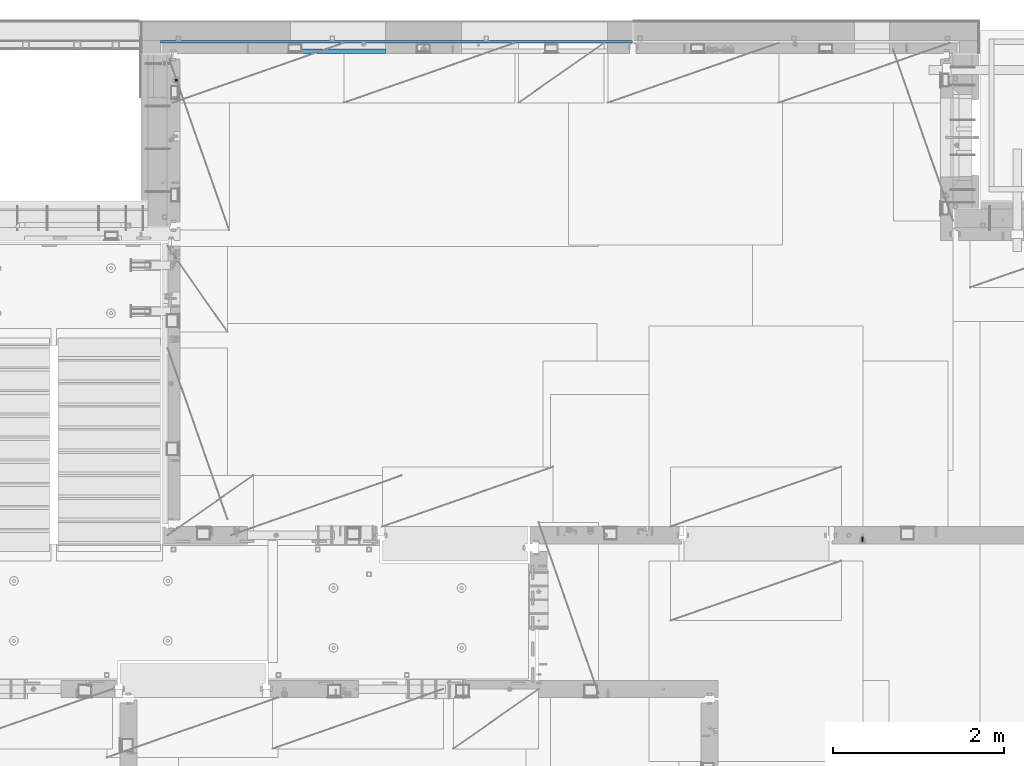
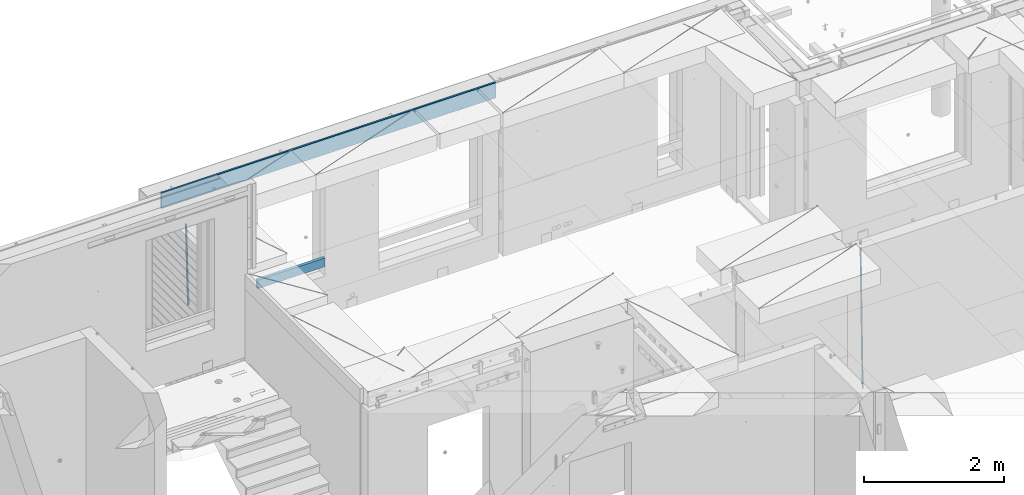
# One storey, part 126 of 350: 4 beams, 3 elements without a shape of their own.
"""IFC2X3 building model written with IfcOpenShell, lengths in millimetres."""

from ifc_helpers import new_model, si_unit, frame, origin_with_axes, place, context, subcontext, project, spatial, faceted_brep, material, type_object, element, aggregate, save


model = new_model("IFC2X3")

# Units and contexts
model_context = context("Model", 3, precision=1e-05, world=origin_with_axes())
body_context = subcontext(model_context, "Body", "Model", "MODEL_VIEW")
ifc_project = project(units=[si_unit("LENGTHUNIT", "METRE", prefix="MILLI"), si_unit("AREAUNIT", "SQUARE_METRE"), si_unit("VOLUMEUNIT", "CUBIC_METRE"), si_unit("MASSUNIT", "GRAM", prefix="KILO"), si_unit("TIMEUNIT", "SECOND"), si_unit("PLANEANGLEUNIT", "RADIAN"), si_unit("SOLIDANGLEUNIT", "STERADIAN"), si_unit("THERMODYNAMICTEMPERATUREUNIT", "DEGREE_CELSIUS"), si_unit("LUMINOUSINTENSITYUNIT", "LUMEN")], contexts=[model_context])

# Site, building, storey
site_placement = place(None, origin_with_axes())
site = spatial("IfcSite", under=ifc_project, at=site_placement, CompositionType="ELEMENT")
building_placement = place(site_placement, origin_with_axes())
building = spatial("IfcBuilding", under=site, at=building_placement, CompositionType="ELEMENT")
storey_placement = place(building_placement, origin_with_axes())
storey = spatial("IfcBuildingStorey", under=building, at=storey_placement, Name="2", CompositionType="ELEMENT", Elevation=0.0)

# Assembly, beam
assembly_1_placement = place(storey_placement, origin_with_axes())
assembly_1 = element("IfcElementAssembly", 1, at=assembly_1_placement, inside=storey, AssemblyPlace="NOTDEFINED", PredefinedType="REINFORCEMENT_UNIT")
ifc_material_1 = material()
beam_type_1 = type_object("IfcBeamType", Name="D20", PredefinedType="NOTDEFINED")
beam_1_placement = place(assembly_1_placement, frame((30400.0000000039, 16915.0002418615, 84990.0), z_axis=(-0.000205762999925498, 0.999642804629538, -0.0267249099901004), x_axis=(4.30000201928125e-08, 0.0267249099948059, 0.999642825806181)))
beam_1 = element("IfcBeam", 2, at=beam_1_placement, type_object=beam_type_1, material=ifc_material_1, Name="JM20", ObjectType="D20", context=body_context, shape_type="Brep", body=[
    faceted_brep([(0.0, -10.0, 0.0), (-4.19531716033816e-08, -7.07106781186667, -7.07106781187031), (60.4266690400545, -7.0710677960451, -7.07106780570757), (60.4266690441291, -9.99999998418934, 6.15546014159918e-09), (0.0, 0.0, -10.0), (60.426669036824, 1.58106558956206e-08, -9.99999999384454), (4.196772351861e-08, 7.07106781186303, -7.07106781186667), (60.4266690363438, 7.07106782768096, -7.07106780570757), (0.0, 10.0, 0.0), (60.4266690388904, 10.0000000158179, 6.15182216279209e-09), (4.196772351861e-08, 7.07106781185939, 7.07106781185939), (60.4266690429649, 7.07106782768096, 7.07106781802577), (0.0, 0.0, 10.0), (60.4266690461809, 1.58179318532348e-08, 10.0000000061555), (-4.19531716033816e-08, -7.07106781187031, 7.07106781185939), (60.4266690466611, -7.07106779605238, 7.07106781802213), (61.0378400410118, -7.07106779588503, -7.07106780564936), (60.991799419251, -9.99999998403655, 6.21366780251265e-09), (61.0569027789461, 1.5985278878361e-08, -9.99999999378269), (61.0378209396877, 7.07106782784831, -7.07106780564936), (60.9917724058905, 10.0000000159635, 6.21366780251265e-09), (60.9457317841297, 7.07106782781193, 7.0710678180767), (60.9266690461809, 1.59488990902901e-08, 10.0000000062028), (60.9457508854539, -7.07106779591413, 7.0710678180767), (61.6489592143771, -7.07106614513759, -7.06310863441468), (61.5568818710308, -9.9999984576425, 0.00735959856683621), (61.6870830769039, 1.71821739058942e-06, -9.99179257185824), (61.6489210170112, 7.07106947854481, -7.06310888312146), (61.556827851804, 10.0000015422847, 0.00735924683976918), (61.4647505084577, 7.07106922979438, 7.07782747982128), (61.4266266459163, 1.36643211590126e-06, 10.0065114172685), (61.464788705809, -7.07106639389531, 7.07782772852806), (176.543135720174, -7.07075579406956, -5.56673531796696), (176.451058376813, -9.99968810657447, 1.50373291501455), (176.581259582701, 0.000312069292704109, -8.49541925541052), (176.543097522794, 7.07137982961285, -5.56673556667374), (176.451004357587, 10.00031189336, 1.50373256329476), (176.35892701424, 7.07137958085514, 8.57420079627263), (176.320803151699, 0.000311717507429421, 11.5028847337162), (176.358965211621, -7.07075604281999, 8.57420104497578), (177.098753836006, -7.07075429323595, -5.55949898843028), (176.98362511232, -9.99968666800123, 1.510669025065), (177.146421932586, 0.000313595905026887, -8.48805862247536), (177.098706077581, 7.07138133041735, -5.55949936166144), (176.983557571715, 10.0003133318824, 1.51066849724157), (176.868428848029, 7.07138095712435, 8.58083651073321), (176.820760751449, 0.000313067976094317, 11.5093961447819), (176.868476606425, -7.07075466652896, 8.58083688396073), (177.654312950661, -7.07075204110879, -5.54863964998367), (177.516135294456, -9.99968450931192, 1.52107783331303), (177.711524267797, 0.000315886711177882, -8.47701274570863), (177.654255632195, 7.07138358250813, -5.54864021007961), (177.516054233929, 10.0003154905207, 1.5210770412159), (177.377876577739, 7.0713830223176, 8.59079452451624), (177.320665260588, 0.000315094497636892, 11.5191676202448), (177.377933896176, -7.07075260129932, 8.59079508461218), (299.499456785634, -7.07025810522464, -3.16697112782276), (299.361279129444, -9.99919057342777, 3.90274635547394), (299.556668102785, 0.000809822595329024, -6.09534422354773), (299.499399467197, 7.07187751838501, -3.1669716879187), (299.361198068917, 10.0008094264049, 3.90274556338045), (299.223020412712, 7.07187695819448, 10.9724630466735), (299.165809095575, 0.000809030381788034, 13.9008361423985), (299.223077731163, -7.07025866542244, 10.9724636067695), (300.03174732349, -7.07025594743027, -3.15656661289177), (299.971788958996, -9.99918809853989, 3.91467979818117), (300.056572611924, 0.000811849109595641, -6.08557274808481), (300.031722507032, 7.07187967631762, -3.15656653768019), (299.971753863239, 10.0008119014747, 3.91467990454839), (299.91179549876, 7.07187975035777, 10.9859263156177), (299.886970210311, 0.000811953817901667, 13.9149324508144), (299.911820315203, -7.0702558733974, 10.9859262404061), (300.564137759997, -7.07025623699155, -3.15794273276697), (300.582413367199, -9.99918843065097, 3.91310145956595), (300.556570941641, 0.000811577163403854, -6.0868651410201), (300.564145451674, 7.07187938674906, -3.15794274158179), (300.582424244858, 10.0008115693345, 3.91310144710224), (300.600699852032, 7.07187937566778, 10.9841456394352), (300.608266670402, 0.000811561512819026, 13.9130680476919), (300.600692160384, -7.07025624805829, 10.98414564825), (2294.16589219622, -7.0713405251372, -8.31099358700158), (2294.1841678034, -10.0002727187966, -1.23994939466866), (2294.15832537785, -0.000272710982244462, -11.2399159952547), (2294.16589988787, 7.07079509858886, -8.31099359582004), (2294.18417868105, 9.99972728118883, -1.23994940713601), (2294.20245428824, 7.07079508752213, 5.83109478519327), (2294.2100211066, -0.00027272663282929, 8.76001719345368), (2294.20244659658, -7.07134053620393, 5.83109479401173), (2294.7782683276, -7.07134085819416, -8.31257645345977), (2294.72126025338, -10.000273010919, -1.24133766827799), (2294.84007459224, -0.000273081772320438, -11.2416781768807), (2294.87047377572, 7.07079471537872, -8.31281477453012), (2294.85165844864, 9.9997269181622, -1.24167470516841), (2294.7946503744, 7.07079476544459, 5.82956408001337), (2294.73284410976, -0.000273010977252852, 8.75866580342336), (2294.7024449263, -7.07134080815013, 5.82980240107645), (2295.39054023061, -7.0793250091956, -8.30442771922026), (2295.25826128852, -10.0072756143927, -1.23419071494573), (2295.52170777075, -0.00916171800054144, -11.2326063125765), (2295.57492774284, 7.06160849139269, -8.30343918807193), (2295.51902460904, 9.99102432676591, -1.23279272078435), (2295.38674566693, 7.06307372157607, 5.83744428349019), (2295.25557812679, -0.0070895696117077, 8.76562287684646), (2295.20235815471, -7.07785977901949, 5.83645575234186), (2317.1947101649, -7.36365585014573, -8.01423575520312), (2317.06243122277, -10.2916064553428, -0.94399875092131), (2317.32587770502, -0.293492558957951, -10.9424143485521), (2317.37909767711, 6.77727765044983, -8.01324722405116), (2317.32319454331, 9.70669348581578, -0.942600756767206), (2317.1909156012, 6.77874288063322, 6.12763624751096), (2317.05974806109, -0.291420410569117, 9.0558148408636), (2317.00652808898, -7.36219061996962, 6.12664771636264), (2317.83015404257, -7.37194216843636, -8.00577862486898), (2317.72252095213, -10.300214160583, -0.935213608652703), (2317.90419832576, -0.301033978277701, -10.9347174723516), (2317.90127966482, 6.77046829039318, -8.00629749759901), (2317.82310777172, 9.70017451494641, -0.935947405505431), (2317.71547468127, 6.77190252279979, 6.13461761071085), (2317.64143039809, -0.29900566735887, 9.06355645819713), (2317.64434905903, -7.37050793602975, 6.13513648344451), (2318.46565174212, -7.3700661537805, -7.99751648408346), (2318.38266643914, -10.2982456018653, -0.926623872735945), (2318.48256818345, -0.299336209594912, -10.9272153854981), (2318.42350634121, 6.77200652527245, -7.99954269419686), (2318.32306384158, 9.70166538090416, -0.929489366557391), (2318.2400785386, 6.77348593281204, 6.14140324480104), (2318.22316209726, -0.297244011366274, 9.07110214621207), (2318.2822239395, -7.36858674623363, 6.1434294549108), (2418.48643733139, -7.07180401323421, -6.70013846199799), (2418.4034520284, -9.99998346132634, 0.370754149349523), (2418.5033537727, -0.00107406904135132, -9.62983736341266), (2418.44429193046, 7.07026866581873, -6.70216467211139), (2418.34384943081, 9.99992752145772, 0.367888655531715), (2418.26086412782, 7.0717480733656, 7.43878126688651), (2418.24394768651, 0.00101812917273492, 10.3684801682975), (2418.30300952874, -7.07032460568735, 7.44080747699627)], [[[0, 1, 2, 3]], [[1, 4, 5, 2]], [[4, 6, 7, 5]], [[6, 8, 9, 7]], [[8, 10, 11, 9]], [[10, 12, 13, 11]], [[12, 14, 15, 13]], [[14, 0, 3, 15]], [[14, 12, 10, 8, 6, 4, 1, 0]], [[3, 2, 16, 17]], [[2, 5, 18, 16]], [[5, 7, 19, 18]], [[7, 9, 20, 19]], [[9, 11, 21, 20]], [[11, 13, 22, 21]], [[13, 15, 23, 22]], [[15, 3, 17, 23]], [[17, 16, 24, 25]], [[16, 18, 26, 24]], [[18, 19, 27, 26]], [[19, 20, 28, 27]], [[20, 21, 29, 28]], [[21, 22, 30, 29]], [[22, 23, 31, 30]], [[23, 17, 25, 31]], [[25, 24, 32, 33]], [[24, 26, 34, 32]], [[26, 27, 35, 34]], [[27, 28, 36, 35]], [[28, 29, 37, 36]], [[29, 30, 38, 37]], [[30, 31, 39, 38]], [[31, 25, 33, 39]], [[33, 32, 40, 41]], [[32, 34, 42, 40]], [[34, 35, 43, 42]], [[35, 36, 44, 43]], [[36, 37, 45, 44]], [[37, 38, 46, 45]], [[38, 39, 47, 46]], [[39, 33, 41, 47]], [[41, 40, 48, 49]], [[40, 42, 50, 48]], [[42, 43, 51, 50]], [[43, 44, 52, 51]], [[44, 45, 53, 52]], [[45, 46, 54, 53]], [[46, 47, 55, 54]], [[47, 41, 49, 55]], [[49, 48, 56, 57]], [[48, 50, 58, 56]], [[50, 51, 59, 58]], [[51, 52, 60, 59]], [[52, 53, 61, 60]], [[53, 54, 62, 61]], [[54, 55, 63, 62]], [[55, 49, 57, 63]], [[57, 56, 64, 65]], [[56, 58, 66, 64]], [[58, 59, 67, 66]], [[59, 60, 68, 67]], [[60, 61, 69, 68]], [[61, 62, 70, 69]], [[62, 63, 71, 70]], [[63, 57, 65, 71]], [[65, 64, 72, 73]], [[64, 66, 74, 72]], [[66, 67, 75, 74]], [[67, 68, 76, 75]], [[68, 69, 77, 76]], [[69, 70, 78, 77]], [[70, 71, 79, 78]], [[71, 65, 73, 79]], [[73, 72, 80, 81]], [[72, 74, 82, 80]], [[74, 75, 83, 82]], [[75, 76, 84, 83]], [[76, 77, 85, 84]], [[77, 78, 86, 85]], [[78, 79, 87, 86]], [[79, 73, 81, 87]], [[81, 80, 88, 89]], [[80, 82, 90, 88]], [[82, 83, 91, 90]], [[83, 84, 92, 91]], [[84, 85, 93, 92]], [[85, 86, 94, 93]], [[86, 87, 95, 94]], [[87, 81, 89, 95]], [[89, 88, 96, 97]], [[88, 90, 98, 96]], [[90, 91, 99, 98]], [[91, 92, 100, 99]], [[92, 93, 101, 100]], [[93, 94, 102, 101]], [[94, 95, 103, 102]], [[95, 89, 97, 103]], [[97, 96, 104, 105]], [[96, 98, 106, 104]], [[98, 99, 107, 106]], [[99, 100, 108, 107]], [[100, 101, 109, 108]], [[101, 102, 110, 109]], [[102, 103, 111, 110]], [[103, 97, 105, 111]], [[105, 104, 112, 113]], [[104, 106, 114, 112]], [[106, 107, 115, 114]], [[107, 108, 116, 115]], [[108, 109, 117, 116]], [[109, 110, 118, 117]], [[110, 111, 119, 118]], [[111, 105, 113, 119]], [[113, 112, 120, 121]], [[112, 114, 122, 120]], [[114, 115, 123, 122]], [[115, 116, 124, 123]], [[116, 117, 125, 124]], [[117, 118, 126, 125]], [[118, 119, 127, 126]], [[119, 113, 121, 127]], [[121, 120, 128, 129]], [[120, 122, 130, 128]], [[122, 123, 131, 130]], [[123, 124, 132, 131]], [[124, 125, 133, 132]], [[125, 126, 134, 133]], [[126, 127, 135, 134]], [[127, 121, 129, 135]], [[130, 131, 132, 133, 134, 135, 129, 128]]]),
])
aggregate(assembly_1, [beam_1])

assembly_2_placement = place(storey_placement, origin_with_axes())
assembly_2 = element("IfcElementAssembly", 3, at=assembly_2_placement, inside=storey, Name="(PD)", AssemblyPlace="NOTDEFINED", PredefinedType="REINFORCEMENT_UNIT")
beam_type_2 = type_object("IfcBeamType", Name="D25", PredefinedType="NOTDEFINED")
beam_2_placement = place(assembly_2_placement, frame((22375.0000022791, 22305.0000022831, 85990.0), z_axis=(-0.999642804636942, -0.000205726999925762, -0.0267249099902983), x_axis=(-0.0267249099948371, 4.30000201934385e-08, 0.999642825806181)))
beam_2 = element("IfcBeam", 4, at=beam_2_placement, type_object=beam_type_2, material=ifc_material_1, Name="JM25", ObjectType="D25", context=body_context, shape_type="Brep", body=[
    faceted_brep([(-7.41420080885291e-08, -12.5, -3.63797880709171e-12), (-6.42030499875546e-08, -10.8253175473074, -6.25000000000364), (60.4103898235917, -10.8253175318459, -6.2499999938409), (60.4103898269532, -12.4999999845422, 6.16273609921336e-09), (-3.70782800018787e-08, -6.25000000000364, -10.8253175473074), (60.4103898202884, -6.24999998454587, -10.8253175411446), (-1.45519152283669e-11, -3.63797880709171e-12, -12.5), (60.4103898179019, 1.54577719513327e-08, -12.4999999938373), (3.70637280866504e-08, 6.25, -10.8253175473074), (60.410389817087, 6.25000001545777, -10.825317541141), (6.42030499875546e-08, 10.8253175473001, -6.25000000000364), (60.410389818062, 10.8253175627578, -6.24999999383726), (7.41420080885291e-08, 12.4999999999927, 0.0), (60.4103898205503, 12.5000000154541, 6.16273609921336e-09), (6.42176019027829e-08, 10.8253175473001, 6.24999999999636), (60.4103898238973, 10.8253175627651, 6.2500000061591), (3.70928319171071e-08, 6.24999999999636, 10.8253175473037), (60.4103898272151, 6.25000001546141, 10.8253175534664), (1.45519152283669e-11, -3.63797880709171e-12, 12.4999999999964), (60.4103898296162, 1.54541339725256e-08, 12.5000000061591), (-3.7049176171422e-08, -6.25000000000364, 10.8253175473001), (60.4103898304165, -6.24999998454587, 10.8253175534701), (-6.41884980723262e-08, -10.8253175473074, 6.25), (60.4103898294561, -10.8253175318459, 6.25000000616637), (61.0324985728803, -10.8253175316895, -6.24999999377542), (60.991802792938, -12.4999999843931, 6.22458173893392e-09), (61.0622854283865, -6.24999998437852, -10.8253175410755), (61.0731819955545, 1.5628756955266e-08, -12.4999999937718), (61.0622685480339, 6.25000001562512, -10.8253175410791), (61.032469335245, 10.8253175629216, -6.24999999377178), (60.9917690322181, 12.5000000156033, 6.22458173893392e-09), (60.9510732522613, 10.8253175629034, 6.25000000621731), (60.9212863967696, 6.25000001558874, 10.8253175535247), (60.9103898296162, 1.55814632307738e-08, 12.5000000062137), (60.9213032771368, -6.24999998441126, 10.8253175535174), (60.9511024898966, -10.8253175317113, 6.25000000621731), (61.6545545670233, -10.8253158516927, -6.24189838219536), (61.573166454793, -12.499998414296, 0.00757164385504439), (61.7141257553885, -6.24999822394238, -10.8168280205282), (61.7359179680789, 1.80548886419274e-06, -12.491368569139), (61.7140919992817, 6.25000177601396, -10.8168282403167), (61.6544960997562, 10.8253192428383, -6.2418987628771), (61.5730989426083, 12.5000015856094, 0.0075712042817031), (61.4917108303925, 10.8253190230062, 6.25704123032847), (61.4321396420273, 6.25000139525582, 10.8319708686649), (61.4103474293224, 1.36582457344048e-06, 12.5065114172721), (61.4321733981196, -6.24999860470052, 10.8319710884571), (61.4917692976451, -10.8253160715249, 6.25704161101385), (176.524302641745, -10.8250056210964, -4.74584321979273), (176.442914529529, -12.4996881836996, 1.50362680625403), (176.583873830095, -6.24968799334965, -9.3207728581292), (176.605666042786, 0.000312036081595579, -10.9953134067364), (176.583840074018, 6.25031200660669, -9.32077307791769), (176.524244174492, 10.8256294734347, -4.74584360047811), (176.44284701733, 12.5003118162058, 1.50362636668069), (176.361458905099, 10.8256292535989, 7.75309639272746), (176.301887716749, 6.25031162585219, 12.3280260310676), (176.280095504058, 0.000311596420942806, 14.0025665796711), (176.301921472827, -6.24968837410415, 12.3280262508561), (176.361517372367, -10.8250058409321, 7.75309677341284), (177.085397012124, -10.8250041057399, -4.73853556792164), (176.983633547483, -12.4996867233749, 1.51066909103247), (177.159881729676, -6.24968643771717, -9.31327097355097), (177.187129580227, 0.000313606451527448, -10.987740468332), (177.159839524218, 6.25031356221734, -9.31327130338468), (177.085323910098, 10.8256309887511, -4.73853613920801), (176.983549136537, 12.5003132764905, 1.51066843136869), (176.881785671867, 10.8256306588555, 7.7598730903228), (176.80730095433, 6.25031299082912, 12.3346084959521), (176.780053103794, 0.000312946667690994, 14.0090779907332), (176.807343159802, -6.2496870091054, 12.3346088257895), (176.881858773908, -10.8250044356355, 7.7598736616128), (177.646431799818, -10.8250018318176, -4.72756919822132), (177.524295146417, -12.4996845320202, 1.52123723245313), (177.735828462886, -6.24968410334986, -9.30201312475765), (177.768531371941, 0.00031596292683389, -10.9763759912421), (177.735777808921, 6.25031589654827, -9.30201361973741), (177.646344064575, 10.8256332626152, -4.72757005553649), (177.524193838486, 12.5003154677688, 1.52123624250817), (177.402057185071, 10.8256327675663, 7.77004267317898), (177.312660521988, 6.2503150390985, 12.3444865997226), (177.279957612933, 0.00031497282179771, 14.0188494661961), (177.312711175953, -6.24968496079964, 12.3444870946951), (177.402144920314, -10.8250023268702, 7.77004353049415), (299.450416306776, -10.8245081491878, -2.34670520440704), (299.32827965336, -12.4991908493976, 3.9021012262674), (299.539812969844, -6.24919042071997, -6.92114913095065), (299.572515878914, 0.000809645553090377, -8.59551199742418), (299.539762315893, 6.25080957917817, -6.9211496259195), (299.450328571547, 10.8261269452451, -2.34670606172585), (299.328178345429, 12.5008091504023, 3.9021002363188), (299.206041692043, 10.8261264501925, 10.1509066669969), (299.11664502896, 6.25080872172475, 14.7253505935405), (299.083942119891, 0.000808655455330154, 16.3997134600104), (299.116695682911, -6.24919127817338, 14.7253510885093), (299.206129427272, -10.8245086442366, 10.1509075243121), (300.022114107283, -10.8245058320463, -2.33553040816332), (299.97179243555, -12.4991882411778, 3.91467976726199), (300.058946494231, -6.24918831662217, -6.9110017919993), (300.072420388053, 0.000811671710835071, -8.58574052196127), (300.058925469799, 6.25081168339239, -6.91100170781283), (300.022077691901, 10.8261292625939, -2.33553026234586), (299.971750386685, 12.5008117588586, 3.91467993563856), (299.921428714966, 10.8261293497235, 10.1648901110639), (299.884596327989, 6.25081183430666, 14.7403614948998), (299.871122434168, 0.000811845966381952, 16.4151002248582), (299.884617352436, -6.24918816571881, 14.7403614107134), (299.921465130334, -10.8245057449167, 10.1648899652428), (300.593917726728, -10.8245062259339, -2.33749813354007), (300.615424329342, -12.4991886845492, 3.91246486206001), (300.578176108116, -6.24918867429733, -6.91278859651356), (300.572417427509, 0.00081132728519151, -8.58746114217138), (300.578184718717, 6.25081132569903, -6.91278861431056), (300.59393264071, 10.8261288686736, -2.33749816436102), (300.615441550515, 12.5008113154472, 3.91246482646966), (300.636948153115, 10.8261288568356, 10.1624278220661), (300.652689771727, 6.25081130520266, 14.7377182850432), (300.658448452334, 0.000811303612863412, 16.4123908306974), (300.65268116114, -6.24918869479734, 14.7377183028366), (300.636933239148, -10.8245062377719, 10.162427852887), (1293.8225958722, -10.8251904135213, -5.7554570479515), (1293.84410247482, -12.4998728721366, 0.494505947652215), (1293.80685425361, -6.2498728618848, -10.330747510925), (1293.801095573, 0.000127139694086509, -12.0054200565755), (1293.80686286419, 6.25012713810793, -10.3307475287183), (1293.82261078618, 10.8254446810788, -5.75545707877609), (1293.84411969599, 12.5001271278561, 0.49450591205823), (1293.86562629859, 10.8254446692445, 6.7444689076583), (1293.8813679172, 6.25012711760428, 11.3197593706318), (1293.88712659782, 0.00012711602539639, 12.994431916286), (1293.88135930662, -6.24987288238844, 11.3197593884252), (1293.86561138462, -10.8251904253593, 6.7444689384829), (1294.43576264779, -10.8251908359052, -5.75756711474241), (1294.39401066334, -12.4998732509448, 0.492613570157118), (1294.4881651176, -6.24987333120953, -10.3330920792978), (1294.53717687333, 0.000126632643514313, -12.0079531043048), (1294.56966525462, 6.25012661264918, -10.3333725306838), (1294.5769250259, 10.8254441614699, -5.75805287079493), (1294.55701093735, 12.5001266367835, 0.492052667374082), (1294.51525895292, 10.825444221744, 6.74223335227362), (1294.46285648308, 6.25012671704826, 11.3177583168253), (1294.41384472734, 0.000126753191580065, 12.9926193418323), (1294.38135634607, -6.24987322681045, 11.318038768215), (1294.37409657479, -10.8251907756348, 6.74271910832613), (1295.04882664244, -10.8331853159034, -5.74940783883358), (1294.94382667454, -12.5070429642874, 0.499931077909423), (1295.16936177819, -6.25875627512141, -10.3240260249331), (1295.27313478947, -0.00947040924438625, -11.9981582317523), (1295.33233978174, 6.24018118068125, -10.3232220864411), (1295.33111282514, 10.8156093981706, -5.74801537651729), (1295.26978268167, 12.4908319473179, 0.501538954897114), (1295.16478271378, 10.8169742989339, 6.75087787164011), (1295.04424757806, 6.24254525814467, 11.3254960577397), (1294.94047456676, -0.00674060772507801, 12.9996282645552), (1294.88126957447, -6.25639219765071, 11.3246921192476), (1294.88249653111, -10.8318204151437, 6.74948540932019), (1316.80386422646, -11.116875459662, -5.45986978806832), (1316.69886425855, -12.790733108046, 0.789469128674682), (1316.92439936219, -6.54244641887635, -10.0344879741715), (1317.02817237348, -0.293160553006601, -11.7086201809871), (1317.08737736575, 5.95649103692267, -10.0336840356795), (1317.08615040916, 10.5319192544084, -5.45847732575203), (1317.02482026568, 12.2071418035557, 0.791077005658735), (1316.91982029779, 10.5332841551717, 7.0404159223981), (1316.79928516207, 5.9588551143861, 11.6150341085013), (1316.69551215076, -0.290430751483655, 13.2891663153168), (1316.63630715849, -6.54008234141656, 11.6142301700129), (1316.6375341151, -11.1155105589023, 7.03902346008545), (1317.48953548315, -11.1258167532178, -5.45074418126023), (1317.39899812841, -12.7998629970425, 0.798787218573125), (1317.57265877169, -6.55089985429368, -10.0258602820722), (1317.62609517592, -0.300957588759047, -11.7006624193855), (1317.63552645453, 5.94934306058713, -10.0263887130131), (1317.59842550401, 10.5252390823007, -5.4516594505003), (1317.52473349411, 12.2006228327155, 0.79773035668768), (1317.43419613934, 10.5265765888907, 7.0472617565174), (1317.35107285083, 5.95165968996662, 11.6223778573367), (1317.2976364466, -0.29828257556801, 13.2971799946463), (1317.28820516799, -6.54858322491418, 11.6229062882776), (1317.32530611851, -11.1244792466277, 7.04817702575747), (1318.17526469367, -11.1237887330935, -5.44182040245869), (1318.09919107273, -12.797775016028, 0.807903115066438), (1318.22097315147, -6.5489957269856, -10.0174341323618), (1318.22406890181, -0.299208089221793, -11.6929060708244), (1318.18372244084, 5.95094862978294, -10.0192948650074), (1318.11074457024, 10.526749984605, -5.44504328594121), (1318.02468965146, 12.2021136975018, 0.804181649778911), (1317.94861603052, 10.52812741456, 7.05390516730768), (1317.90290757272, 5.95333440845207, 11.6295188972072), (1317.8998118224, -0.296453229308099, 13.3049908356734), (1317.94015828335, -6.54660994831283, 11.6313796298491), (1318.01313615397, -11.1224113031385, 7.0571280507902), (1418.17602640855, -10.8255863639497, -4.14470589025586), (1418.09995278763, -12.4995726468842, 2.10501762727654), (1418.22173486637, -6.25079335783812, -8.72031962014808), (1418.2248306167, -0.00100572007431765, -10.3957915586216), (1418.18448415573, 6.24915099893042, -8.72218035279366), (1418.11150628512, 10.8249523537488, -4.14792877373111), (1418.02545136634, 12.500316066642, 2.10129616199265), (1417.94937774542, 10.8263297837075, 8.35101967951414), (1417.90366928761, 6.2515367775959, 12.9266334094173), (1417.90057353729, 0.00174913983573788, 14.6021053478798), (1417.94091999825, -6.248407579169, 12.9284941420592), (1418.01389786886, -10.824208933991, 8.35424256299666)], [[[0, 1, 2, 3]], [[1, 4, 5, 2]], [[4, 6, 7, 5]], [[6, 8, 9, 7]], [[8, 10, 11, 9]], [[10, 12, 13, 11]], [[12, 14, 15, 13]], [[14, 16, 17, 15]], [[16, 18, 19, 17]], [[18, 20, 21, 19]], [[20, 22, 23, 21]], [[22, 0, 3, 23]], [[22, 20, 18, 16, 14, 12, 10, 8, 6, 4, 1, 0]], [[3, 2, 24, 25]], [[2, 5, 26, 24]], [[5, 7, 27, 26]], [[7, 9, 28, 27]], [[9, 11, 29, 28]], [[11, 13, 30, 29]], [[13, 15, 31, 30]], [[15, 17, 32, 31]], [[17, 19, 33, 32]], [[19, 21, 34, 33]], [[21, 23, 35, 34]], [[23, 3, 25, 35]], [[25, 24, 36, 37]], [[24, 26, 38, 36]], [[26, 27, 39, 38]], [[27, 28, 40, 39]], [[28, 29, 41, 40]], [[29, 30, 42, 41]], [[30, 31, 43, 42]], [[31, 32, 44, 43]], [[32, 33, 45, 44]], [[33, 34, 46, 45]], [[34, 35, 47, 46]], [[35, 25, 37, 47]], [[37, 36, 48, 49]], [[36, 38, 50, 48]], [[38, 39, 51, 50]], [[39, 40, 52, 51]], [[40, 41, 53, 52]], [[41, 42, 54, 53]], [[42, 43, 55, 54]], [[43, 44, 56, 55]], [[44, 45, 57, 56]], [[45, 46, 58, 57]], [[46, 47, 59, 58]], [[47, 37, 49, 59]], [[49, 48, 60, 61]], [[48, 50, 62, 60]], [[50, 51, 63, 62]], [[51, 52, 64, 63]], [[52, 53, 65, 64]], [[53, 54, 66, 65]], [[54, 55, 67, 66]], [[55, 56, 68, 67]], [[56, 57, 69, 68]], [[57, 58, 70, 69]], [[58, 59, 71, 70]], [[59, 49, 61, 71]], [[61, 60, 72, 73]], [[60, 62, 74, 72]], [[62, 63, 75, 74]], [[63, 64, 76, 75]], [[64, 65, 77, 76]], [[65, 66, 78, 77]], [[66, 67, 79, 78]], [[67, 68, 80, 79]], [[68, 69, 81, 80]], [[69, 70, 82, 81]], [[70, 71, 83, 82]], [[71, 61, 73, 83]], [[73, 72, 84, 85]], [[72, 74, 86, 84]], [[74, 75, 87, 86]], [[75, 76, 88, 87]], [[76, 77, 89, 88]], [[77, 78, 90, 89]], [[78, 79, 91, 90]], [[79, 80, 92, 91]], [[80, 81, 93, 92]], [[81, 82, 94, 93]], [[82, 83, 95, 94]], [[83, 73, 85, 95]], [[85, 84, 96, 97]], [[84, 86, 98, 96]], [[86, 87, 99, 98]], [[87, 88, 100, 99]], [[88, 89, 101, 100]], [[89, 90, 102, 101]], [[90, 91, 103, 102]], [[91, 92, 104, 103]], [[92, 93, 105, 104]], [[93, 94, 106, 105]], [[94, 95, 107, 106]], [[95, 85, 97, 107]], [[97, 96, 108, 109]], [[96, 98, 110, 108]], [[98, 99, 111, 110]], [[99, 100, 112, 111]], [[100, 101, 113, 112]], [[101, 102, 114, 113]], [[102, 103, 115, 114]], [[103, 104, 116, 115]], [[104, 105, 117, 116]], [[105, 106, 118, 117]], [[106, 107, 119, 118]], [[107, 97, 109, 119]], [[109, 108, 120, 121]], [[108, 110, 122, 120]], [[110, 111, 123, 122]], [[111, 112, 124, 123]], [[112, 113, 125, 124]], [[113, 114, 126, 125]], [[114, 115, 127, 126]], [[115, 116, 128, 127]], [[116, 117, 129, 128]], [[117, 118, 130, 129]], [[118, 119, 131, 130]], [[119, 109, 121, 131]], [[121, 120, 132, 133]], [[120, 122, 134, 132]], [[122, 123, 135, 134]], [[123, 124, 136, 135]], [[124, 125, 137, 136]], [[125, 126, 138, 137]], [[126, 127, 139, 138]], [[127, 128, 140, 139]], [[128, 129, 141, 140]], [[129, 130, 142, 141]], [[130, 131, 143, 142]], [[131, 121, 133, 143]], [[133, 132, 144, 145]], [[132, 134, 146, 144]], [[134, 135, 147, 146]], [[135, 136, 148, 147]], [[136, 137, 149, 148]], [[137, 138, 150, 149]], [[138, 139, 151, 150]], [[139, 140, 152, 151]], [[140, 141, 153, 152]], [[141, 142, 154, 153]], [[142, 143, 155, 154]], [[143, 133, 145, 155]], [[145, 144, 156, 157]], [[144, 146, 158, 156]], [[146, 147, 159, 158]], [[147, 148, 160, 159]], [[148, 149, 161, 160]], [[149, 150, 162, 161]], [[150, 151, 163, 162]], [[151, 152, 164, 163]], [[152, 153, 165, 164]], [[153, 154, 166, 165]], [[154, 155, 167, 166]], [[155, 145, 157, 167]], [[157, 156, 168, 169]], [[156, 158, 170, 168]], [[158, 159, 171, 170]], [[159, 160, 172, 171]], [[160, 161, 173, 172]], [[161, 162, 174, 173]], [[162, 163, 175, 174]], [[163, 164, 176, 175]], [[164, 165, 177, 176]], [[165, 166, 178, 177]], [[166, 167, 179, 178]], [[167, 157, 169, 179]], [[169, 168, 180, 181]], [[168, 170, 182, 180]], [[170, 171, 183, 182]], [[171, 172, 184, 183]], [[172, 173, 185, 184]], [[173, 174, 186, 185]], [[174, 175, 187, 186]], [[175, 176, 188, 187]], [[176, 177, 189, 188]], [[177, 178, 190, 189]], [[178, 179, 191, 190]], [[179, 169, 181, 191]], [[181, 180, 192, 193]], [[180, 182, 194, 192]], [[182, 183, 195, 194]], [[183, 184, 196, 195]], [[184, 185, 197, 196]], [[185, 186, 198, 197]], [[186, 187, 199, 198]], [[187, 188, 200, 199]], [[188, 189, 201, 200]], [[189, 190, 202, 201]], [[190, 191, 203, 202]], [[191, 181, 193, 203]], [[194, 195, 196, 197, 198, 199, 200, 201, 202, 203, 193, 192]]]),
])
aggregate(assembly_2, [beam_2])

# Assembly, beams
assembly_3_placement = place(storey_placement, origin_with_axes())
assembly_3 = element("IfcElementAssembly", 5, at=assembly_3_placement, inside=storey, AssemblyPlace="NOTDEFINED", PredefinedType="REINFORCEMENT_UNIT")
ifc_material_2 = material(Name="TIMBER/T24")
beam_type_3 = type_object("IfcBeamType", PredefinedType="NOTDEFINED")
beam_3_placement = place(assembly_3_placement, frame((24815.0002989914, 22644.9998418812, 85685.0), z_axis=(0.0, 0.0, 1.0), x_axis=(-1.0, 3.00000001838171e-08, 0.0)))
beam_3 = element("IfcBeam", 6, at=beam_3_placement, type_object=beam_type_3, material=ifc_material_2, context=body_context, shape_type="Brep", body=[
    faceted_brep([(-3.63797880709171e-12, 24.9999999999964, -75.0), (-3.63797880709171e-12, 24.9999999999964, 75.0), (1110.0, 24.9999999999964, 75.0), (1110.0, 24.9999999999964, -75.0), (0.0, -25.0000000000073, 75.0), (1110.0, -25.0000000000073, 75.0), (0.0, -25.0000000000073, -75.0), (1110.0, -25.0000000000073, -75.0)], [[[0, 1, 2, 3]], [[1, 4, 5, 2]], [[4, 6, 7, 5]], [[6, 0, 3, 7]], [[5, 7, 3, 2]], [[6, 4, 1, 0]]]),
])
ifc_material_3 = material(Name="CONCRETE/C25/30")
beam_type_4 = type_object("IfcBeamType", Name="270X30", PredefinedType="NOTDEFINED")
beam_4_placement = place(assembly_3_placement, frame((27705.0, 22755.0, 87605.0), z_axis=(0.0, 0.0, 1.0), x_axis=(-1.0, 3.00000001838171e-08, 0.0)))
beam_4 = element("IfcBeam", 7, at=beam_4_placement, type_object=beam_type_4, material=ifc_material_3, ObjectType="270X30", context=body_context, shape_type="Brep", body=[
    faceted_brep([(0.0, 15.0, -135.0), (0.0, 15.0, 135.0), (5520.00000000003, 15.0, 135.0), (5520.00000000003, 15.0, -135.0), (0.0, -15.0, 135.0), (5520.00000000003, -15.0, 135.0), (0.0, -15.0, -135.0), (5520.00000000003, -15.0, -135.0)], [[[0, 1, 2, 3]], [[1, 4, 5, 2]], [[4, 6, 7, 5]], [[6, 0, 3, 7]], [[5, 7, 3, 2]], [[6, 4, 1, 0]]]),
])
aggregate(assembly_3, [beam_4, beam_3])

save(model, "model.ifc")
